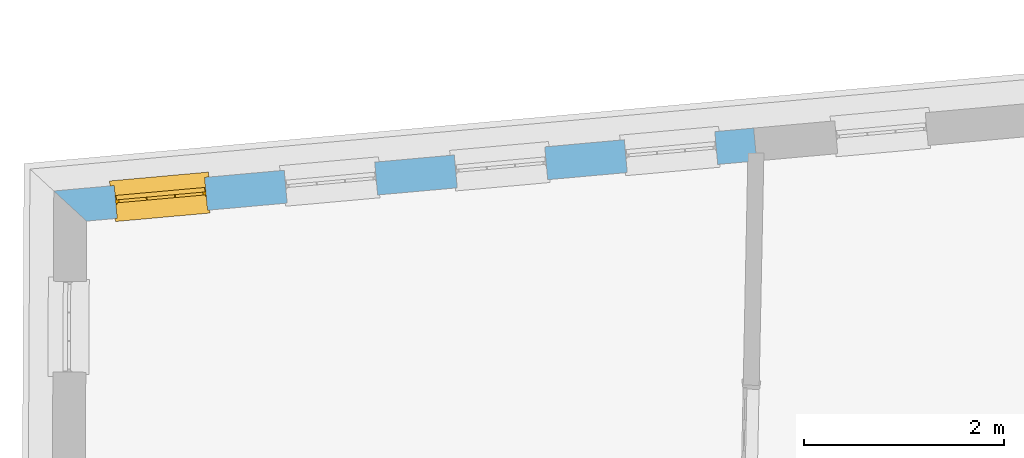
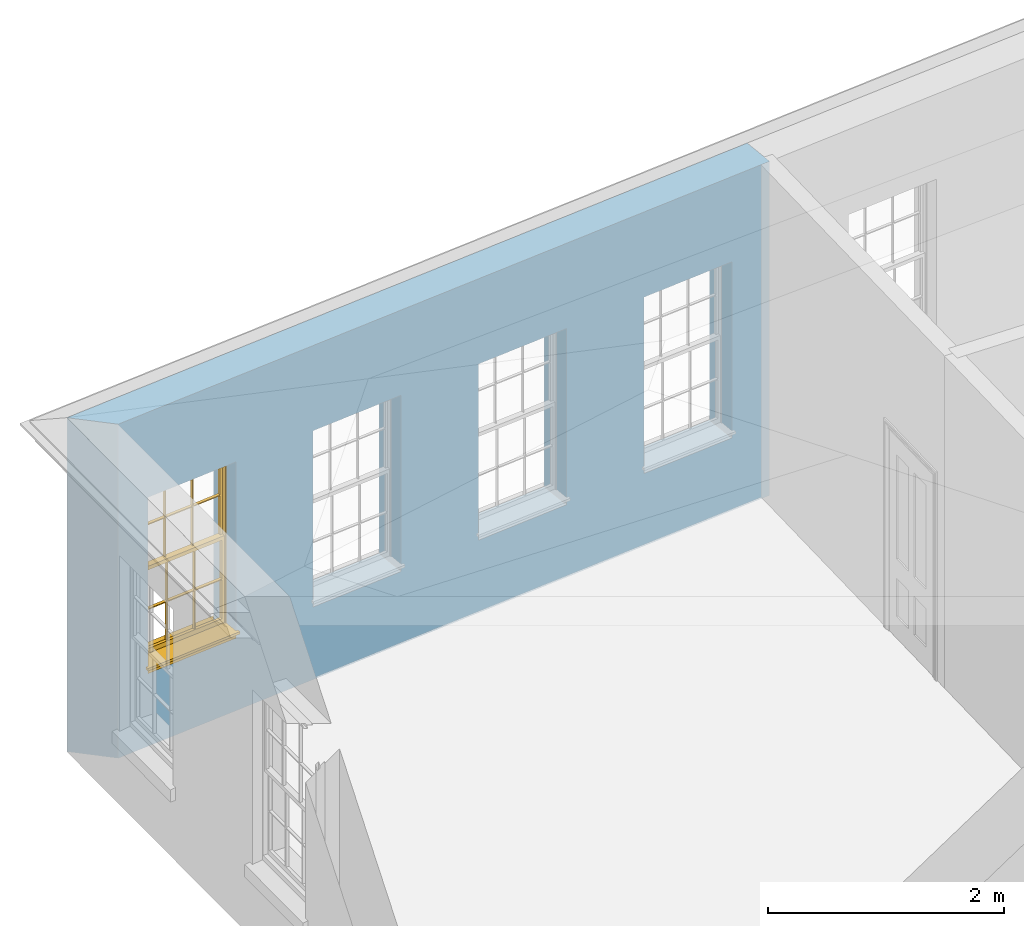
# One storey, part 6 of 14: 1 window, 4 openings, plus 1 element that does not belong to this part.
"""IFC2X3 building model written with IfcOpenShell, lengths in metres."""

from ifc_helpers import new_model, si_unit, frame, origin, place, context, subcontext, project, spatial, polyline, outline, extrude, faceted_brep, material, layer, layer_set, layer_usage, element, fill, save


model = new_model("IFC2X3")

# Units and contexts
model_context = context("Model", 3, world=origin())
body_context = subcontext(model_context, "Body", "Model", "MODEL_VIEW")
ifc_project = project(units=[si_unit("PLANEANGLEUNIT", "RADIAN"), si_unit("MASSUNIT", "GRAM", prefix="KILO"), si_unit("FORCEUNIT", "NEWTON", prefix="KILO"), si_unit("LENGTHUNIT", "METRE")], contexts=[model_context])

# Site, building, storey
site_placement = place(None, origin())
site = spatial("IfcSite", under=ifc_project, at=site_placement, CompositionType="ELEMENT")
building_placement = place(None, origin())
building = spatial("IfcBuilding", under=site, at=building_placement, Name="Building plot-17", CompositionType="ELEMENT")
storey_placement = place(None, frame((0.0, 0.0, 6.15)))
storey = spatial("IfcBuildingStorey", under=building, at=storey_placement, Name="Floor 1", CompositionType="ELEMENT", Elevation=6.15)

# Wall, openings, window
ifc_material = material(Name="Masonry")
ifc_layer = layer(ifc_material, 0.33, ventilated=False)
ifc_layer_set = layer_set([ifc_layer], Name="My Wall")
ifc_layer_usage = layer_usage(ifc_layer_set, "AXIS2", "NEGATIVE", 0.08)
wall_placement = place(storey_placement, origin())
wall = element("IfcWallStandardCase", 1, at=wall_placement, inside=storey, material=ifc_layer_usage, Name="exterior", context=body_context, shape_type="SweptSolid", body=[
    extrude(outline(polyline([(77.4514973462638, 26.0607374425634), (77.4219746484992, 26.3894141991445), (70.4115738095909, 25.7597197013384), (70.7400454135505, 25.4578954009408), (77.4514973462638, 26.0607374425634)])), origin(), (0.0, 0.0, 1.0), 3.45),
])
opening_1_placement = place(storey_placement, frame((0.0, 0.0, 0.75)))
element("IfcOpeningElement", 2, at=opening_1_placement, cuts=wall, Name="Opening", ObjectType="Opening", context=body_context, shape_type="SweptSolid", body=[
    extrude(outline(polyline([(77.0323071544384, 26.354413136777), (76.1259560984116, 26.273002061123), (76.1554787961762, 25.9443253045419), (77.061829852203, 26.0257363801958), (77.0323071544384, 26.354413136777)])), origin(), (0.0, 0.0, 1.0), 1.82),
])
opening_2_placement = place(storey_placement, frame((0.0, 0.0, 0.75)))
element("IfcOpeningElement", 3, at=opening_2_placement, cuts=wall, Name="Opening", ObjectType="Opening", context=body_context, shape_type="SweptSolid", body=[
    extrude(outline(polyline([(75.3291639612452, 26.201431884724), (74.4228129052184, 26.12002080907), (74.452335602983, 25.7913440524889), (75.3586866590098, 25.8727551281428), (75.3291639612452, 26.201431884724)])), origin(), (0.0, 0.0, 1.0), 1.82),
])
opening_3_placement = place(storey_placement, frame((0.0, 0.0, 0.75)))
element("IfcOpeningElement", 4, at=opening_3_placement, cuts=wall, Name="Opening", ObjectType="Opening", context=body_context, shape_type="SweptSolid", body=[
    extrude(outline(polyline([(73.626020768052, 26.0484506326709), (72.7196697120252, 25.967039557017), (72.7491924097898, 25.6383628004358), (73.6555434658166, 25.7197738760898), (73.626020768052, 26.0484506326709)])), origin(), (0.0, 0.0, 1.0), 1.82),
])
opening_4_placement = place(storey_placement, frame((0.0, 0.0, 0.75)))
opening_4 = element("IfcOpeningElement", 5, at=opening_4_placement, cuts=wall, Name="Opening", ObjectType="Opening", context=body_context, shape_type="SweptSolid", body=[
    extrude(outline(polyline([(71.9228775748588, 25.8954693806179), (71.016526518832, 25.814058304964), (71.0460492165967, 25.4853815483828), (71.9524002726234, 25.5667926240368), (71.9228775748588, 25.8954693806179)])), origin(), (0.0, 0.0, 1.0), 1.82),
])
window_placement = place(storey_placement, frame((71.9452432549835, 25.6464718377534, 0.75), z_axis=(0.0, 0.0, 1.0), x_axis=(-0.906351056026779, -0.0814110756539463, 0.0)))
window = element("IfcWindow", 6, at=window_placement, inside=storey, Name="bedroom outside window", OverallHeight=1.82, OverallWidth=0.91, context=body_context, shape_type="Brep", held_by="IfcProductRepresentation", body=[
    faceted_brep([(0.033125, -0.105, 0.975209), (0.01, -0.105, 0.975209), (0.033125, -0.105, 1.376042), (0.876875, -0.105, 0.975209), (0.876875, -0.105, 1.376042), (0.9, -0.105, 0.975209), (0.876875, -0.105, 1.386042), (0.876875, -0.105, 1.786875), (0.9, -0.105, 1.81), (0.033125, -0.105, 1.786875), (0.033125, -0.105, 1.386042), (0.01, -0.105, 1.81), (0.876875, -0.135, 1.376042), (0.876875, -0.135, 0.975209), (0.9, -0.135, 0.937083), (0.033125, -0.135, 1.786875), (0.01, -0.135, 1.81), (0.033125, -0.135, 1.386042), (0.01, -0.135, 0.937083), (0.033125, -0.135, 0.975209), (0.033125, -0.135, 1.376042), (0.876875, -0.135, 1.786875), (0.876875, -0.135, 1.386042), (0.9, -0.135, 1.81), (0.033125, -0.105, 0.937083), (0.01, -0.105, 0.937083), (0.033125, -0.105, 0.53625), (0.876875, -0.105, 0.937083), (0.876875, -0.105, 0.53625), (0.9, -0.105, 0.937083), (0.876875, -0.105, 0.52625), (0.876875, -0.105, 0.125417), (0.9, -0.105, 0.077167), (0.033125, -0.105, 0.125417), (0.033125, -0.105, 0.52625), (0.01, -0.105, 0.077167), (-0.0425, -0.25, 0.01), (-0.0425, -0.3, 0.001667), (0.0, -0.25, 0.01), (0.9525, -0.25, 0.01), (0.91, -0.25, 0.01), (0.9525, -0.3, 0.001667), (-0.02, 0.08, 0.077167), (0.0, 0.08, 0.077167), (-0.02, 0.11, 0.077167), (0.0, -0.06, 0.077167), (0.01, -0.06, 0.077167), (0.91, -0.06, 0.077167), (0.91, 0.08, 0.077167), (0.9, -0.06, 0.077167), (0.93, 0.08, 0.077167), (0.93, 0.11, 0.077167), (0.01, -0.075, 0.975209), (0.9, -0.075, 0.975209), (0.876875, -0.075, 0.125417), (0.876875, -0.075, 0.52625), (0.9, -0.075, 0.077167), (0.876875, -0.075, 0.53625), (0.876875, -0.075, 0.937083), (0.033125, -0.075, 0.125417), (0.01, -0.075, 0.077167), (0.033125, -0.075, 0.52625), (0.033125, -0.075, 0.937083), (0.033125, -0.075, 0.53625), (-0.02, 0.08, 0.052167), (-0.02, 0.11, 0.052167), (0.93, 0.11, 0.052167), (0.93, 0.08, 0.052167), (0.91, 0.08, 0.052167), (0.0, 0.08, 0.052167), (0.91, -0.15, 0.026667), (0.0, -0.15, 0.026667), (-0.0425, -0.3, -0.123333), (0.9525, -0.3, -0.123333), (-0.0425, -0.25, -0.123333), (0.9525, -0.25, -0.123333), (0.01, -0.06, 1.81), (0.9, -0.06, 1.81), (0.0, -0.06, 1.82), (0.91, -0.06, 1.82), (0.01, -0.15, 0.077167), (0.9, -0.15, 0.077167), (0.592292, -0.105, 0.125417), (0.592292, -0.075, 0.125417), (0.317708, -0.075, 0.125417), (0.317708, -0.105, 0.125417), (0.592292, -0.105, 0.53625), (0.317708, -0.105, 0.53625), (0.317708, -0.105, 0.52625), (0.592292, -0.105, 0.52625), (0.592292, -0.075, 0.53625), (0.317708, -0.075, 0.53625), (0.592292, -0.135, 1.386042), (0.592292, -0.105, 1.386042), (0.317708, -0.105, 1.386042), (0.317708, -0.135, 1.386042), (0.317708, -0.135, 1.376042), (0.592292, -0.135, 1.376042), (0.317708, -0.105, 1.376042), (0.592292, -0.105, 1.376042), (0.602292, -0.135, 1.376042), (0.592292, -0.135, 0.975209), (0.602292, -0.135, 0.975209), (0.602292, -0.105, 0.975209), (0.592292, -0.105, 0.975209), (0.602292, -0.105, 1.376042), (0.602292, -0.075, 0.53625), (0.602292, -0.105, 0.53625), (0.317708, -0.075, 0.52625), (0.307708, -0.075, 0.125417), (0.307708, -0.075, 0.52625), (0.602292, -0.075, 0.52625), (0.602292, -0.075, 0.125417), (0.592292, -0.075, 0.52625), (0.307708, -0.075, 0.53625), (0.317708, -0.075, 0.937083), (0.307708, -0.075, 0.937083), (0.602292, -0.075, 0.937083), (0.592292, -0.075, 0.937083), (0.307708, -0.105, 0.52625), (0.307708, -0.105, 0.125417), (0.307708, -0.105, 0.53625), (0.307708, -0.105, 0.937083), (0.592292, -0.105, 0.937083), (0.317708, -0.105, 0.937083), (0.602292, -0.105, 0.937083), (0.602292, -0.105, 0.52625), (0.602292, -0.105, 0.125417), (0.307708, -0.135, 1.386042), (0.307708, -0.135, 1.376042), (0.307708, -0.135, 0.975209), (0.317708, -0.135, 0.975209), (0.317708, -0.135, 1.786875), (0.307708, -0.135, 1.786875), (0.602292, -0.135, 1.786875), (0.592292, -0.135, 1.786875), (0.602292, -0.135, 1.386042), (0.602292, -0.105, 1.386042), (0.307708, -0.105, 1.386042), (0.307708, -0.105, 1.786875), (0.317708, -0.105, 1.786875), (0.592292, -0.105, 1.786875), (0.602292, -0.105, 1.786875), (0.307708, -0.105, 1.376042), (0.317708, -0.105, 0.975209), (0.307708, -0.105, 0.975209), (0.91, -0.15, 1.82), (0.9, -0.15, 1.81), (0.01, -0.15, 1.81), (0.0, -0.15, 1.82), (0.91, -0.25, 0.0), (0.0, -0.25, 0.0), (0.91, 0.08, 0.0), (0.0, 0.08, 0.0)], [[[0, 1, 2]], [[3, 4, 5]], [[6, 7, 8]], [[9, 10, 11]], [[12, 13, 14]], [[15, 16, 17]], [[18, 19, 20]], [[21, 22, 23]], [[24, 25, 26]], [[27, 28, 29]], [[30, 31, 32]], [[33, 34, 35]], [[14, 27, 29]], [[25, 24, 18]], [[36, 37, 38]], [[39, 40, 41]], [[42, 43, 44]], [[45, 46, 43]], [[47, 48, 49]], [[50, 51, 48]], [[1, 0, 52]], [[5, 53, 3]], [[54, 55, 56]], [[57, 58, 53]], [[59, 60, 61]], [[62, 63, 52]], [[48, 43, 46, 49]], [[51, 44, 43, 48]], [[64, 42, 44, 65]], [[65, 44, 51, 66]], [[66, 51, 50, 67]], [[65, 66, 68, 69]], [[60, 56, 49, 46]], [[70, 71, 38, 40]], [[37, 41, 40, 38]], [[37, 72, 73, 41]], [[74, 75, 73, 72]], [[8, 11, 76, 77]], [[76, 78, 79, 77]], [[32, 35, 80, 81]], [[81, 80, 71, 70]], [[82, 83, 84, 85]], [[86, 87, 88, 89]], [[86, 90, 91, 87]], [[92, 93, 94, 95]], [[92, 95, 96, 97]], [[96, 98, 99, 97]], [[100, 97, 101, 102]], [[103, 104, 99, 105]], [[97, 99, 104, 101]], [[102, 103, 105, 100]], [[28, 57, 106, 107]], [[108, 84, 109, 110]], [[111, 112, 83, 113]], [[114, 110, 61, 63]], [[90, 113, 108, 91]], [[115, 91, 114, 116]], [[117, 106, 90, 118]], [[111, 106, 57, 55]], [[119, 110, 109, 120]], [[34, 61, 110, 119]], [[89, 113, 83, 82]], [[88, 108, 113, 89]], [[85, 84, 108, 88]], [[121, 114, 63, 26]], [[122, 116, 114, 121]], [[123, 118, 90, 86]], [[87, 91, 115, 124]], [[107, 106, 117, 125]], [[126, 111, 55, 30]], [[127, 112, 111, 126]], [[126, 30, 28, 107]], [[88, 119, 120, 85]], [[126, 89, 82, 127]], [[125, 123, 86, 107]], [[121, 26, 34, 119]], [[124, 122, 121, 87]], [[128, 17, 20, 129]], [[96, 129, 130, 131]], [[132, 133, 128, 95]], [[134, 135, 92, 136]], [[100, 12, 22, 136]], [[137, 6, 4, 105]], [[94, 138, 139, 140]], [[137, 93, 141, 142]], [[99, 98, 94, 93]], [[143, 2, 10, 138]], [[144, 145, 143, 98]], [[129, 143, 145, 130]], [[20, 2, 143, 129]], [[131, 144, 98, 96]], [[128, 138, 10, 17]], [[133, 139, 138, 128]], [[135, 141, 93, 92]], [[95, 94, 140, 132]], [[22, 6, 137, 136]], [[136, 137, 142, 134]], [[100, 105, 4, 12]], [[107, 86, 89, 126]], [[106, 111, 113, 90]], [[91, 108, 110, 114]], [[87, 121, 119, 88]], [[97, 100, 136, 92]], [[129, 96, 95, 128]], [[98, 143, 138, 94]], [[105, 99, 93, 137]], [[131, 101, 104, 144]], [[124, 115, 118, 123]], [[132, 140, 141, 135]], [[120, 109, 59, 33]], [[15, 9, 139, 133]], [[134, 142, 7, 21]], [[31, 54, 112, 127]], [[36, 74, 72, 37]], [[39, 41, 73, 75]], [[18, 14, 101, 131]], [[23, 16, 132, 135]], [[83, 56, 60, 84]], [[52, 53, 118, 115]], [[53, 52, 144, 104]], [[11, 8, 141, 140]], [[14, 18, 124, 123]], [[2, 1, 11, 10]], [[8, 5, 4, 6]], [[57, 53, 56, 55]], [[60, 52, 63, 61]], [[26, 25, 35, 34]], [[32, 29, 28, 30]], [[14, 23, 22, 12]], [[18, 20, 17, 16]], [[19, 0, 2, 20]], [[17, 10, 9, 15]], [[12, 4, 3, 13]], [[21, 7, 6, 22]], [[27, 58, 57, 28]], [[30, 55, 54, 31]], [[33, 59, 61, 34]], [[26, 63, 62, 24]], [[5, 8, 77, 53]], [[76, 11, 1, 52]], [[46, 45, 78, 76]], [[49, 77, 79, 47]], [[70, 146, 147, 81]], [[71, 80, 148, 149]], [[19, 130, 145, 0]], [[102, 13, 3, 103]], [[116, 122, 24, 62]], [[29, 32, 81, 14]], [[80, 35, 25, 18]], [[60, 46, 76, 52]], [[77, 49, 56, 53]], [[23, 14, 81, 147]], [[16, 148, 80, 18]], [[35, 85, 120]], [[120, 33, 35]], [[127, 82, 32]], [[32, 31, 127]], [[32, 82, 85, 35]], [[102, 101, 14]], [[14, 13, 102]], [[18, 131, 130]], [[130, 19, 18]], [[134, 21, 23]], [[23, 135, 134]], [[16, 15, 133]], [[133, 132, 16]], [[11, 140, 139]], [[139, 9, 11]], [[142, 141, 8]], [[8, 7, 142]], [[23, 147, 148, 16]], [[146, 149, 148, 147]], [[52, 115, 116]], [[116, 62, 52]], [[118, 53, 117]], [[58, 117, 53]], [[27, 125, 117, 58]], [[56, 83, 112]], [[112, 54, 56]], [[109, 84, 60]], [[60, 59, 109]], [[125, 27, 14]], [[14, 123, 125]], [[122, 124, 18]], [[18, 24, 122]], [[145, 144, 52]], [[52, 0, 145]], [[103, 3, 53]], [[53, 104, 103]], [[79, 78, 149, 146]], [[78, 45, 71, 149]], [[146, 70, 47, 79]], [[150, 75, 74, 151]], [[68, 66, 67]], [[48, 68, 67, 50]], [[69, 64, 65]], [[42, 64, 69, 43]], [[69, 68, 152, 153]], [[70, 68, 48, 47]], [[150, 152, 68, 70]], [[43, 69, 71, 45]], [[69, 153, 151, 71]], [[152, 150, 151, 153]], [[38, 151, 74, 36]], [[71, 151, 38]], [[39, 75, 150, 40]], [[40, 150, 70]]]),
])
fill(opening_4, window)

save(model, "model.ifc")
